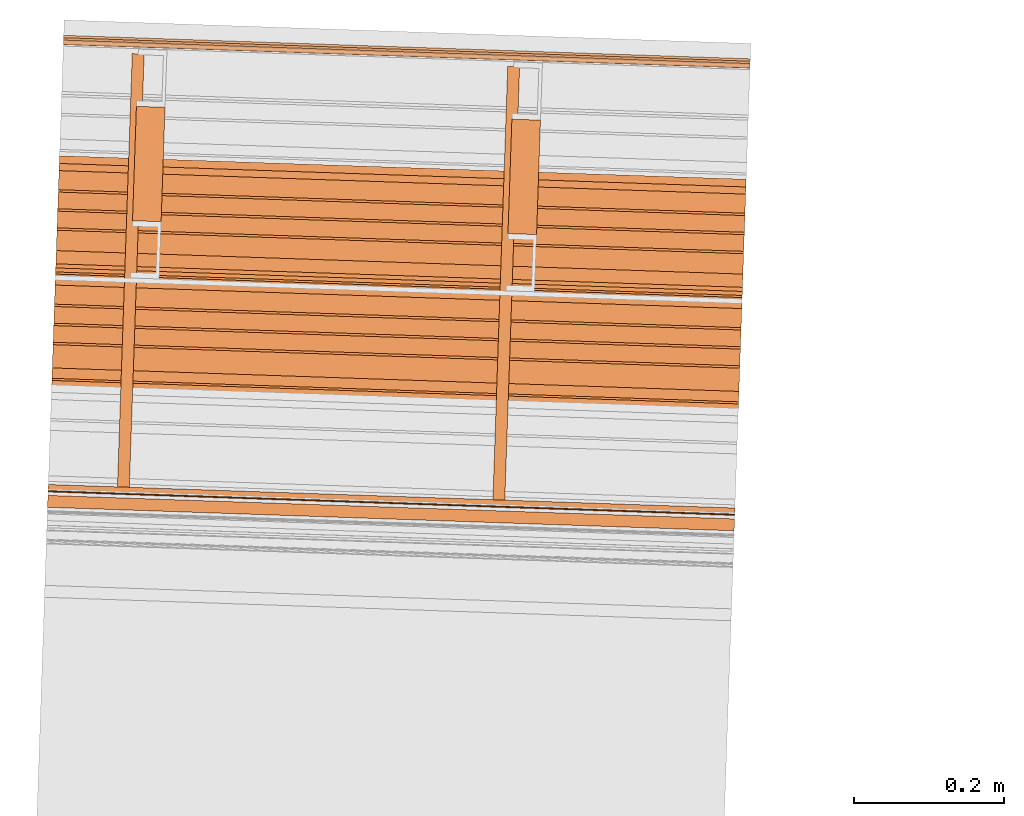
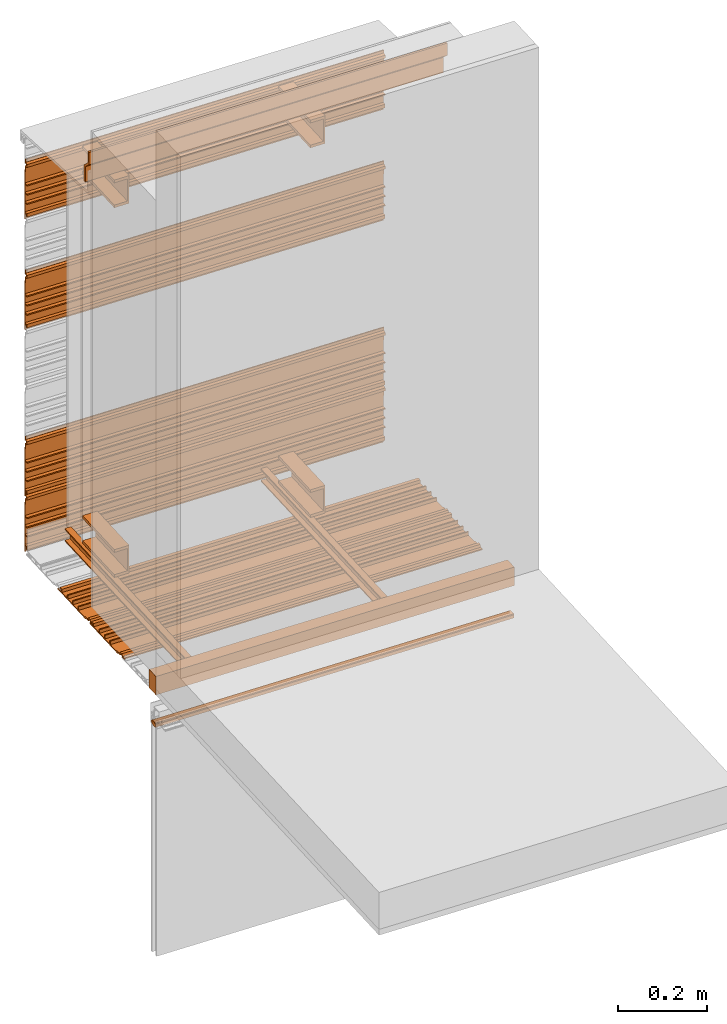
# One storey, part 4 of 6: 17 proxies.
"""IFC2X3 building model written with IfcOpenShell, lengths in feet."""

import ifcopenshell
import ifcopenshell.guid

model = None  # the IFC model being written
_history = None  # IfcOwnerHistory: only IFC2X3 demands one
_inside = {}  # id of a spatial element -> (the spatial element, [elements in it])
_under = {}  # id of a project, library or spatial element -> (it, [spatial elements below it])
_declared = {}  # id of a project -> (the project, [libraries it declares])
_typed = {}  # id of a type object -> (the type object, [elements of that type])
_made_of = {}  # id of a material, layer set ... -> (it, [elements and type objects made of it])


def new_model(schema):
    """Start an empty IFC model of exactly this schema.

    Asked for "IFC4X3", IfcOpenShell would pick the latest addendum, in which some entities
    have other attributes; the version numbers below select the first issue.
    IFC2X3 requires an IfcOwnerHistory on every rooted entity: one is made here for all.
    """
    global model, _history
    if schema == "IFC4X3":
        model = ifcopenshell.file(schema_version=(4, 3, 0, 0))
    else:
        model = ifcopenshell.file(schema=schema)
    _inside.clear()
    _under.clear()
    _declared.clear()
    _typed.clear()
    _made_of.clear()
    _history = None
    if model.schema == "IFC2X3":
        org = make("IfcOrganization", Name="unknown")
        user = make(
            "IfcPersonAndOrganization",
            ThePerson=make("IfcPerson", FamilyName="unknown"),
            TheOrganization=org,
        )
        app = make(
            "IfcApplication",
            ApplicationDeveloper=org,
            Version="unknown",
            ApplicationFullName="unknown",
            ApplicationIdentifier="unknown",
        )
        _history = make(
            "IfcOwnerHistory",
            OwningUser=user,
            OwningApplication=app,
            ChangeAction="ADDED",
            CreationDate=0,
        )
    return model


def make(cls, **values):
    """One entity of the class cls with the attributes given. An attribute that is None is left unset."""
    return model.create_entity(
        cls, **{name: value for name, value in values.items() if value is not None}
    )


def entity(cls, *values):
    """Any entity or typed value of the class cls, its attributes in the order of the schema. None: left unset."""
    e = model.create_entity(cls)
    for i, value in enumerate(values):
        if value is not None:
            e[i] = value
    return e


def rooted(cls, **values):
    """An entity with a GlobalId (a new one), such as an element, a storey or a relation."""
    return make(cls, GlobalId=ifcopenshell.guid.new(), OwnerHistory=_history, **values)


def si_unit(unit_type, name, prefix=None):
    """IfcSIUnit, for example si_unit("LENGTHUNIT", "METRE", prefix="MILLI")."""
    return make("IfcSIUnit", UnitType=unit_type, Prefix=prefix, Name=name)


def converted_unit(unit_type, name, factor, base, dimensions=None, offset=None):
    """IfcConversionBasedUnit, such as the inch: factor (a typed value) times the base unit."""
    return make(
        "IfcConversionBasedUnit"
        if offset is None
        else "IfcConversionBasedUnitWithOffset",
        ConversionOffset=offset,
        Dimensions=None
        if dimensions is None
        else entity("IfcDimensionalExponents", *dimensions),
        UnitType=unit_type,
        Name=name,
        ConversionFactor=make(
            "IfcMeasureWithUnit", ValueComponent=factor, UnitComponent=base
        ),
    )


def derived_unit(unit_type, elements):
    """IfcDerivedUnit: a product of units, each with its exponent."""
    return make(
        "IfcDerivedUnit",
        Elements=[
            make("IfcDerivedUnitElement", Unit=unit, Exponent=power)
            for unit, power in elements
        ],
        UnitType=unit_type,
    )


def assignment(units):
    """IfcUnitAssignment: the units of a project."""
    return None if units is None else make("IfcUnitAssignment", Units=units)


def point(xyz):
    """IfcCartesianPoint."""
    return None if xyz is None else make("IfcCartesianPoint", Coordinates=xyz)


def direction(xyz):
    """IfcDirection."""
    return None if xyz is None else make("IfcDirection", DirectionRatios=xyz)


def frame(location, z_axis=None, x_axis=None):
    """IfcAxis2Placement3D, a coordinate frame: its origin and axes. An axis left out is left unset."""
    return make(
        "IfcAxis2Placement3D",
        Location=point(location),
        Axis=direction(z_axis),
        RefDirection=direction(x_axis),
    )


def frame_2d(location, x_axis=None):
    """IfcAxis2Placement2D, a coordinate frame in the plane: its origin and x axis."""
    return make(
        "IfcAxis2Placement2D", Location=point(location), RefDirection=direction(x_axis)
    )


def origin():
    """The frame at (0, 0, 0) with its axes left unset."""
    return frame((0.0, 0.0, 0.0))


def place(relative_to, where):
    """IfcLocalPlacement: puts the frame where relative to a parent placement (None: the world)."""
    return make(
        "IfcLocalPlacement", PlacementRelTo=relative_to, RelativePlacement=where
    )


def context(
    kind, dimensions, precision=None, world=None, true_north=None, identifier=None
):
    """IfcGeometricRepresentationContext, for example the 3D "Model" context."""
    return make(
        "IfcGeometricRepresentationContext",
        ContextIdentifier=identifier,
        ContextType=kind,
        CoordinateSpaceDimension=dimensions,
        Precision=precision,
        WorldCoordinateSystem=world,
        TrueNorth=true_north,
    )


def subcontext(parent, identifier, kind, view, scale=None):
    """IfcGeometricRepresentationSubContext, for example "Body" below "Model"."""
    return make(
        "IfcGeometricRepresentationSubContext",
        ContextIdentifier=identifier,
        ContextType=kind,
        ParentContext=parent,
        TargetScale=scale,
        TargetView=view,
    )


def project(units=None, contexts=None):
    """IfcProject with its units and contexts."""
    return rooted(
        "IfcProject",
        Name="project",
        RepresentationContexts=contexts,
        UnitsInContext=assignment(units),
    )


def spatial(cls, under=None, at=None, **own):
    """A site, building, storey or space (cls), placed at a placement, below another one or the project."""
    s = rooted(cls, ObjectPlacement=at, **own)
    if under is not None:
        _under.setdefault(under.id(), (under, []))[1].append(s)
    return s


def polyline(points):
    """IfcPolyline through the points."""
    return make("IfcPolyline", Points=[point(p) for p in points])


def circle_curve(where, radius):
    """IfcCircle in the frame where."""
    return make("IfcCircle", Position=where, Radius=radius)


def parameter(value):
    """IfcParameterValue: where a trimmed curve begins or ends, as a parameter of its basis curve."""
    return model.create_entity("IfcParameterValue", value)


def trimmed(basis, trim1, trim2, sense, master):
    """IfcTrimmedCurve: the piece of a basis curve between two trims."""
    return make(
        "IfcTrimmedCurve",
        BasisCurve=basis,
        Trim1=trim1,
        Trim2=trim2,
        SenseAgreement=sense,
        MasterRepresentation=master,
    )


def segment(curve, same_sense, transition):
    """IfcCompositeCurveSegment."""
    return make(
        "IfcCompositeCurveSegment",
        Transition=transition,
        SameSense=same_sense,
        ParentCurve=curve,
    )


def composite_curve(segments, self_intersect=None):
    """IfcCompositeCurve: segments joined end to end."""
    return make("IfcCompositeCurve", Segments=segments, SelfIntersect=self_intersect)


def profile(cls, at=None, kind="AREA", **sizes):
    """A parametric profile (cls). Its sizes go by their IFC names, for example OverallWidth=200.0."""
    return make(cls, ProfileType=kind, Position=at, **sizes)


def rectangle(**sizes):
    """IfcRectangleProfileDef."""
    return profile("IfcRectangleProfileDef", **sizes)


def outline(outer, holes=None, kind="AREA"):
    """IfcArbitraryClosedProfileDef: a profile drawn as a closed curve; with holes, ...WithVoids."""
    if holes is None:
        return make("IfcArbitraryClosedProfileDef", ProfileType=kind, OuterCurve=outer)
    return make(
        "IfcArbitraryProfileDefWithVoids",
        ProfileType=kind,
        OuterCurve=outer,
        InnerCurves=holes,
    )


def extrude(swept, where, along, depth):
    """IfcExtrudedAreaSolid: the profile swept, set in the frame where, extruded along a direction by depth."""
    return make(
        "IfcExtrudedAreaSolid",
        SweptArea=swept,
        Position=where,
        ExtrudedDirection=direction(along),
        Depth=depth,
    )


def shape(context_of_items, identifier, shape_type, items):
    """IfcShapeRepresentation: the items that make up one representation, for example the "Body"."""
    return make(
        "IfcShapeRepresentation",
        ContextOfItems=context_of_items,
        RepresentationIdentifier=identifier,
        RepresentationType=shape_type,
        Items=items,
    )


def source(mapping_origin, context_of_items, identifier, shape_type, items):
    """IfcRepresentationMap: a shape defined once, which mapped items show again and again."""
    return make(
        "IfcRepresentationMap",
        MappingOrigin=mapping_origin,
        MappedRepresentation=shape(context_of_items, identifier, shape_type, items),
    )


def transform(
    local_origin,
    x_axis=None,
    y_axis=None,
    z_axis=None,
    scale=None,
    scale2=None,
    scale3=None,
    uniform=True,
):
    """IfcCartesianTransformationOperator3D, or its non-uniform kind. x_axis, y_axis, z_axis: its Axis1, 2, 3."""
    if uniform:
        return make(
            "IfcCartesianTransformationOperator3D",
            Axis1=direction(x_axis),
            Axis2=direction(y_axis),
            LocalOrigin=point(local_origin),
            Scale=scale,
            Axis3=direction(z_axis),
        )
    return make(
        "IfcCartesianTransformationOperator3DnonUniform",
        Axis1=direction(x_axis),
        Axis2=direction(y_axis),
        LocalOrigin=point(local_origin),
        Scale=scale,
        Axis3=direction(z_axis),
        Scale2=scale2,
        Scale3=scale3,
    )


def mapped(mapping_source, mapping_target):
    """IfcMappedItem: shows the shape of a source again, moved by a transform."""
    return make(
        "IfcMappedItem", MappingSource=mapping_source, MappingTarget=mapping_target
    )


def material(Name=None, Category=None):
    """IfcMaterial."""
    return make("IfcMaterial", Name=Name, Category=Category)


def made_of(thing, what):
    """Note that an element or type object is made of a material, layer set ...; save() writes the relation."""
    if what is not None:
        _made_of.setdefault(what.id(), (what, []))[1].append(thing)
    return thing


def type_object(cls, material=None, **own):
    """A type object (cls), such as IfcWallType, which elements share."""
    return made_of(rooted(cls, **own), material)


def type_shapes(of_type, sources):
    """Give a type object the sources (RepresentationMaps) that its elements show as mapped items."""
    of_type.RepresentationMaps = sources


def element(
    cls,
    number,
    at=None,
    inside=None,
    cuts=None,
    type_object=None,
    material=None,
    context=None,
    identifier="Body",
    shape_type=None,
    held_by="IfcProductDefinitionShape",
    body=None,
    shapes=None,
    **own,
):
    """One element of the class cls, such as IfcWall. Its Tag is "e" and its number.

    at: its placement. inside: the storey or other place that contains it. cuts: it is an
    opening in that element (IfcRelVoidsElement). A single representation is given by context,
    identifier, shape_type and body (its items); several are given by shapes. held_by: the class
    of the entity that holds the representations. save() writes the other relations.
    """
    e = rooted(cls, Tag="e%d" % number, ObjectPlacement=at, **own)
    if body is not None:
        shapes = [shape(context, identifier, shape_type, body)]
    if shapes is not None:
        e.Representation = make(held_by, Representations=shapes)
    if inside is not None:
        _inside.setdefault(inside.id(), (inside, []))[1].append(e)
    if cuts is not None:
        rooted(
            "IfcRelVoidsElement", RelatingBuildingElement=cuts, RelatedOpeningElement=e
        )
    if type_object is not None:
        _typed.setdefault(type_object.id(), (type_object, []))[1].append(e)
    return made_of(e, material)


def aggregate(whole, parts):
    """IfcRelAggregates: a whole, such as a stair, and the parts it consists of."""
    return rooted("IfcRelAggregates", RelatingObject=whole, RelatedObjects=parts)


def save(model, path):
    """Write the relations noted so far, then the file.

    IfcRelAggregates (storeys below a building ...), IfcRelContainedInSpatialStructure (elements
    in a storey), IfcRelDefinesByType, IfcRelAssociatesMaterial and IfcRelDeclares: one each for
    every whole, place, type object, material and project.
    """
    for whole, parts in _under.values():
        aggregate(whole, parts)
    for where, things in _inside.values():
        rooted(
            "IfcRelContainedInSpatialStructure",
            RelatedElements=things,
            RelatingStructure=where,
        )
    for kind, things in _typed.values():
        rooted("IfcRelDefinesByType", RelatedObjects=things, RelatingType=kind)
    for what, things in _made_of.values():
        rooted("IfcRelAssociatesMaterial", RelatedObjects=things, RelatingMaterial=what)
    for by, libraries in _declared.values():
        rooted("IfcRelDeclares", RelatingContext=by, RelatedDefinitions=libraries)
    model.write(path)


model = new_model("IFC2X3")

# Units and contexts
model_context = context("Model", 3, precision=0.0001, world=origin(), true_north=direction((6.12303176911189e-17, 1.0)))
context_of_model = context(None, 3, precision=0.0001, world=origin(), true_north=direction((6.12303176911189e-17, 1.0)))
body_context = subcontext(model_context, "Body", "Model", "MODEL_VIEW")
ifc_project = project(units=[converted_unit("LENGTHUNIT", "FOOT", entity("IfcRatioMeasure", 0.3048), si_unit("LENGTHUNIT", "METRE"), dimensions=[1, 0, 0, 0, 0, 0, 0]), converted_unit("AREAUNIT", "SQUARE FOOT", entity("IfcRatioMeasure", 0.09290304), si_unit("AREAUNIT", "SQUARE_METRE"), dimensions=[2, 0, 0, 0, 0, 0, 0]), si_unit("VOLUMEUNIT", "CUBIC_METRE"), converted_unit("PLANEANGLEUNIT", "DEGREE", entity("IfcRatioMeasure", 0.0174532925199433), si_unit("PLANEANGLEUNIT", "RADIAN"), dimensions=[0, 0, 0, 0, 0, 0, 0]), si_unit("MASSUNIT", "GRAM", prefix="KILO"), derived_unit("MASSDENSITYUNIT", [(si_unit("MASSUNIT", "GRAM", prefix="KILO"), 1), (si_unit("LENGTHUNIT", "METRE"), -3)]), si_unit("TIMEUNIT", "SECOND"), si_unit("FREQUENCYUNIT", "HERTZ"), si_unit("THERMODYNAMICTEMPERATUREUNIT", "DEGREE_CELSIUS"), derived_unit("THERMALTRANSMITTANCEUNIT", [(si_unit("MASSUNIT", "GRAM", prefix="KILO"), 1), (si_unit("THERMODYNAMICTEMPERATUREUNIT", "KELVIN"), -1), (si_unit("TIMEUNIT", "SECOND"), -3)]), derived_unit("VOLUMETRICFLOWRATEUNIT", [(si_unit("LENGTHUNIT", "METRE"), 3), (si_unit("TIMEUNIT", "SECOND"), -1)]), si_unit("ELECTRICCURRENTUNIT", "AMPERE"), si_unit("ELECTRICVOLTAGEUNIT", "VOLT"), si_unit("POWERUNIT", "WATT"), si_unit("FORCEUNIT", "NEWTON"), si_unit("ILLUMINANCEUNIT", "LUX"), si_unit("LUMINOUSFLUXUNIT", "LUMEN"), si_unit("LUMINOUSINTENSITYUNIT", "CANDELA"), derived_unit("USERDEFINED", [(si_unit("MASSUNIT", "GRAM", prefix="KILO"), -1), (si_unit("LENGTHUNIT", "METRE"), -2), (si_unit("TIMEUNIT", "SECOND"), 3), (si_unit("LUMINOUSFLUXUNIT", "LUMEN"), 1)]), derived_unit("LINEARVELOCITYUNIT", [(si_unit("LENGTHUNIT", "METRE"), 1), (si_unit("TIMEUNIT", "SECOND"), -1)]), si_unit("PRESSUREUNIT", "PASCAL"), derived_unit("USERDEFINED", [(si_unit("LENGTHUNIT", "METRE"), -2), (si_unit("MASSUNIT", "GRAM", prefix="KILO"), 1), (si_unit("TIMEUNIT", "SECOND"), -2)])], contexts=[model_context, context_of_model])

# Site, building, storey
site_placement = place(None, origin())
site = spatial("IfcSite", under=ifc_project, at=site_placement, CompositionType="ELEMENT")
building_placement = place(site_placement, origin())
building = spatial("IfcBuilding", under=site, at=building_placement, CompositionType="ELEMENT")
storey_placement = place(building_placement, origin())
storey = spatial("IfcBuildingStorey", under=building, at=storey_placement, Name="Level 1", CompositionType="ELEMENT", Elevation=0.0)

# Proxies
ifc_material_1 = material(Name="IfcSurfaceStyle #179")
building_element_proxy_type_1 = type_object("IfcBuildingElementProxyType", Name="Metal support for window frame001", PredefinedType="NOTDEFINED", material=ifc_material_1)
shared_shape_1 = source(origin(), body_context, "Body", "SweptSolid", [
    extrude(rectangle(XDim=3.0, YDim=0.107278015091847, at=frame_2d((-6.99440505513849e-15, -2.42861286636753e-16), x_axis=(1.0, 0.0))), frame((111.216846057744, -50.6154050021282, 9.70833333333332), z_axis=(0.0, 0.0, 1.0), x_axis=(-0.999414947916634, 0.0342017818364937, 0.0)), (0.0, 0.0, 1.0), 0.166666666666668),
])
type_shapes(building_element_proxy_type_1, [shared_shape_1])
proxy_1_placement = place(storey_placement, origin())
element("IfcBuildingElementProxy", 1, at=proxy_1_placement, inside=storey, type_object=building_element_proxy_type_1, material=ifc_material_1, ObjectType="Metal support for window frame001", context=body_context, shape_type="MappedRepresentation", body=[
    mapped(shared_shape_1, transform((0.0, 0.0, 0.0), scale=1.0)),
])
ifc_material_2 = material(Name="LIGHT GAUGE METAL STUDS AND/OR FURRING")
building_element_proxy_type_2 = type_object("IfcBuildingElementProxyType", Name="Stud 004", PredefinedType="NOTDEFINED", material=ifc_material_2)
shared_shape_2 = source(origin(), body_context, "Body", "SweptSolid", [
    extrude(outline(polyline([(-0.0286458333333562, -0.0572916666666679), (0.0234374999999827, -0.0572916666666679), (0.0234374999999827, -0.046875), (-0.0182291666666801, -0.046875), (-0.0182291666666801, 0.046875), (0.0234374999999827, 0.046875), (0.0234374999999827, 0.0572916666666661), (-0.0286458333333562, 0.0572916666666661), (-0.0286458333333562, -0.0572916666666679)])), frame((110.044847585689, -50.5216266933335, 9.81770833333333), z_axis=(0.0342017818365511, 0.999414947916632, 0.0), x_axis=(-0.999414947916632, 0.0342017818365511, 0.0)), (0.0, 0.0, 1.0), 1.89272198512796),
])
type_shapes(building_element_proxy_type_2, [shared_shape_2])
proxy_2_placement = place(storey_placement, origin())
element("IfcBuildingElementProxy", 2, at=proxy_2_placement, inside=storey, type_object=building_element_proxy_type_2, material=ifc_material_2, Name="Stud 004:Stud 004", ObjectType="Stud 004", context=body_context, shape_type="MappedRepresentation", body=[
    mapped(shared_shape_2, transform((0.0, 0.0, 0.0), scale=1.0)),
])
building_element_proxy_type_3 = type_object("IfcBuildingElementProxyType", Name="Stud 003", PredefinedType="NOTDEFINED", material=ifc_material_2)
shared_shape_3 = source(origin(), body_context, "Body", "SweptSolid", [
    extrude(outline(polyline([(-0.0286458333333278, -0.0572916666666679), (0.023437500000025, -0.0572916666666679), (0.023437500000025, -0.046875), (-0.0182291666666514, -0.046875), (-0.0182291666666514, 0.046875), (0.023437500000025, 0.046875), (0.023437500000025, 0.0572916666666661), (-0.0286458333333278, 0.0572916666666661), (-0.0286458333333278, -0.0572916666666679)])), frame((111.684307802088, -50.5777319784982, 9.81770833333333), z_axis=(0.0342017818364056, 0.999414947916637, 0.0), x_axis=(-0.999414947916637, 0.0342017818364056, 0.0)), (0.0, 0.0, 1.0), 1.89272198512795),
])
type_shapes(building_element_proxy_type_3, [shared_shape_3])
proxy_3_placement = place(storey_placement, origin())
element("IfcBuildingElementProxy", 3, at=proxy_3_placement, inside=storey, type_object=building_element_proxy_type_3, material=ifc_material_2, Name="Stud 003:Stud 003", ObjectType="Stud 003", context=body_context, shape_type="MappedRepresentation", body=[
    mapped(shared_shape_3, transform((0.0, 0.0, 0.0), scale=1.0)),
])
ifc_material_3 = material(Name="METAL STUDS")
building_element_proxy_type_4 = type_object("IfcBuildingElementProxyType", Name="Metal stud 014", PredefinedType="NOTDEFINED", material=ifc_material_3)
shared_shape_4 = source(origin(), body_context, "Body", "SweptSolid", [
    extrude(outline(polyline([(-0.0661909448818519, -0.125), (0.0588090551181219, -0.125), (0.0588090551181219, -0.100393700787402), (-0.0514271653543063, -0.100393700787402), (-0.0514271653543063, 0.100393700787404), (0.0588090551181219, 0.100393700787404), (0.0588090551181219, 0.125000000000002), (-0.0661909448818519, 0.125000000000002), (-0.0661909448818519, -0.125)])), frame((110.146020542697, -49.3608525569486, 10.0), z_axis=(0.0342017818366075, 0.99941494791663, 0.0), x_axis=(-0.99941494791663, 0.0342017818366075, 0.0)), (0.0, 0.0, 1.0), 0.500000000000002),
])
type_shapes(building_element_proxy_type_4, [shared_shape_4])
proxy_4_placement = place(storey_placement, origin())
element("IfcBuildingElementProxy", 4, at=proxy_4_placement, inside=storey, type_object=building_element_proxy_type_4, material=ifc_material_3, Name="Metal stud 014:Metal stud 014", ObjectType="Metal stud 014", context=body_context, shape_type="MappedRepresentation", body=[
    mapped(shared_shape_4, transform((0.0, 0.0, 0.0), scale=1.0)),
])
building_element_proxy_type_5 = type_object("IfcBuildingElementProxyType", Name="Metal stud 011", PredefinedType="NOTDEFINED", material=ifc_material_3)
shared_shape_5 = source(origin(), body_context, "Body", "SweptSolid", [
    extrude(outline(polyline([(-0.0661909448818519, -0.125), (0.0588090551181219, -0.125), (0.0588090551181219, -0.1003937007874), (-0.0514271653543063, -0.1003937007874), (-0.0514271653543063, 0.1003937007874), (0.0588090551181219, 0.1003937007874), (0.0588090551181219, 0.125), (-0.0661909448818519, 0.125), (-0.0661909448818519, -0.125)])), frame((110.146020542697, -49.3608525569486, 13.3333333333333), z_axis=(0.0342017818366075, 0.99941494791663, 0.0), x_axis=(-0.99941494791663, 0.0342017818366075, 0.0)), (0.0, 0.0, 1.0), 0.500000000000002),
])
type_shapes(building_element_proxy_type_5, [shared_shape_5])
proxy_5_placement = place(storey_placement, origin())
element("IfcBuildingElementProxy", 5, at=proxy_5_placement, inside=storey, type_object=building_element_proxy_type_5, material=ifc_material_3, Name="Metal stud 011:Metal stud 011", ObjectType="Metal stud 011", context=body_context, shape_type="MappedRepresentation", body=[
    mapped(shared_shape_5, transform((0.0, 0.0, 0.0), scale=1.0)),
])
building_element_proxy_type_6 = type_object("IfcBuildingElementProxyType", Name="Metal stud 013", PredefinedType="NOTDEFINED", material=ifc_material_3)
shared_shape_6 = source(origin(), body_context, "Body", "SweptSolid", [
    extrude(outline(polyline([(-0.0661909448818803, -0.125), (0.0588090551181075, -0.125), (0.0588090551181075, -0.1003937007874), (-0.0514271653543347, -0.1003937007874), (-0.0514271653543347, 0.1003937007874), (0.0588090551181075, 0.1003937007874), (0.0588090551181075, 0.125), (-0.0661909448818803, 0.125), (-0.0661909448818803, -0.125)])), frame((111.785480759096, -49.4169578421136, 13.3333333333333), z_axis=(0.0342017818365468, 0.999414947916633, 0.0), x_axis=(-0.999414947916633, 0.0342017818365468, 0.0)), (0.0, 0.0, 1.0), 0.500000000000001),
])
type_shapes(building_element_proxy_type_6, [shared_shape_6])
proxy_6_placement = place(storey_placement, origin())
element("IfcBuildingElementProxy", 6, at=proxy_6_placement, inside=storey, type_object=building_element_proxy_type_6, material=ifc_material_3, Name="Metal stud 013:Metal stud 013", ObjectType="Metal stud 013", context=body_context, shape_type="MappedRepresentation", body=[
    mapped(shared_shape_6, transform((0.0, 0.0, 0.0), scale=1.0)),
])
building_element_proxy_type_7 = type_object("IfcBuildingElementProxyType", Name="Metal stud 012", PredefinedType="NOTDEFINED", material=ifc_material_3)
shared_shape_7 = source(origin(), body_context, "Body", "SweptSolid", [
    extrude(outline(polyline([(-0.0661909448818803, -0.125), (0.0588090551181075, -0.125), (0.0588090551181075, -0.100393700787402), (-0.0514271653543347, -0.100393700787402), (-0.0514271653543347, 0.100393700787404), (0.0588090551181075, 0.100393700787404), (0.0588090551181075, 0.125000000000002), (-0.0661909448818803, 0.125000000000002), (-0.0661909448818803, -0.125)])), frame((111.785480759096, -49.4169578421136, 10.0), z_axis=(0.0342017818365468, 0.999414947916633, 0.0), x_axis=(-0.999414947916633, 0.0342017818365468, 0.0)), (0.0, 0.0, 1.0), 0.500000000000001),
])
type_shapes(building_element_proxy_type_7, [shared_shape_7])
proxy_7_placement = place(storey_placement, origin())
element("IfcBuildingElementProxy", 7, at=proxy_7_placement, inside=storey, type_object=building_element_proxy_type_7, material=ifc_material_3, Name="Metal stud 012:Metal stud 012", ObjectType="Metal stud 012", context=body_context, shape_type="MappedRepresentation", body=[
    mapped(shared_shape_7, transform((0.0, 0.0, 0.0), scale=1.0)),
])
ifc_material_4 = material(Name="IMPERMEABLE WRB MEMBRANE")
building_element_proxy_type_8 = type_object("IfcBuildingElementProxyType", Name="Flashing 003", PredefinedType="NOTDEFINED", material=ifc_material_4)
shared_shape_8 = source(origin(), body_context, "Body", "SweptSolid", [
    extrude(outline(polyline([(-0.0371589137820224, 0.0154669259900354), (-0.135772181632417, -0.0923404467542823), (-0.122552267089255, -0.104432931160668), (-0.0292661571907254, -0.00244938836847988), (0.0490662805214159, -0.0024493883946275), (0.123864814921589, 0.0793229091327372), (0.110644900349842, 0.0914153935652706), (0.0411735239015335, 0.0154669259900354), (-0.0371589137820224, 0.0154669259900354)])), frame((109.753215664138, -49.5269849138619, 13.807758480938), z_axis=(-0.999414947916625, 0.0342017818367569, 0.0), x_axis=(-0.025236475786405, -0.737438512825177, 0.674942634667624)), (0.0, 0.0, -1.0), 3.0),
])
type_shapes(building_element_proxy_type_8, [shared_shape_8])
proxy_8_placement = place(storey_placement, origin())
element("IfcBuildingElementProxy", 8, at=proxy_8_placement, inside=storey, type_object=building_element_proxy_type_8, material=ifc_material_4, Name="Flashing 003:Flashing 003", ObjectType="Flashing 003", context=body_context, shape_type="MappedRepresentation", body=[
    mapped(shared_shape_8, transform((0.0, 0.0, 0.0), scale=1.0)),
])
ifc_material_5 = material(Name="Window frame")
building_element_proxy_type_9 = type_object("IfcBuildingElementProxyType", Name="Window frame 017", PredefinedType="NOTDEFINED", material=ifc_material_5)
shared_shape_9 = source(origin(), body_context, "Body", "SweptSolid", [
    extrude(outline(composite_curve([segment(polyline([(-0.0145833333334195, -0.0259583333333165), (0.0145833333334213, -0.0259583333333165)]), True, "CONTINUOUS"), segment(trimmed(circle_curve(frame_2d((-0.118933680555463, 0.0), x_axis=(0.0, -1.0)), 0.13601701388888), [parameter(78.9978270971977)], [parameter(101.002172902812)], True, "PARAMETER"), True, "CONTINUOUS"), segment(polyline([(0.0145833333334178, 0.0259583333333232), (-0.014583333333416, 0.0259583333333232)]), True, "CONTINUOUS"), segment(trimmed(circle_curve(frame_2d((0.118933680555465, 0.0), x_axis=(0.0, -1.0)), 0.13601701388888), [parameter(258.997827097188)], [parameter(281.002172902802)], True, "PARAMETER"), True, "CONTINUOUS")], self_intersect=False)), frame((109.717039781299, -50.5840853372173, 9.42538449904838), z_axis=(0.999414947916641, -0.0342017818362893, 0.0), x_axis=(0.0, 0.0, -1.0)), (0.0, 0.0, 1.0), 3.0),
])
type_shapes(building_element_proxy_type_9, [shared_shape_9])
proxy_9_placement = place(storey_placement, origin())
element("IfcBuildingElementProxy", 9, at=proxy_9_placement, inside=storey, type_object=building_element_proxy_type_9, material=ifc_material_5, Name="Window frame 017:Window frame 017", ObjectType="Window frame 017", context=body_context, shape_type="MappedRepresentation", body=[
    mapped(shared_shape_9, transform((0.0, 0.0, 0.0), scale=1.0)),
])
building_element_proxy_type_10 = type_object("IfcBuildingElementProxyType", Name="Window frame 014", PredefinedType="NOTDEFINED", material=ifc_material_5)
shared_shape_10 = source(origin(), body_context, "Body", "SweptSolid", [
    extrude(rectangle(XDim=3.0, YDim=0.00499999999997292, at=frame_2d((6.99440505513849e-15, 3.7921055184853e-15), x_axis=(1.0, 0.0))), frame((111.217669931724, -50.5913304676835, 9.4124678323819), z_axis=(0.0, 0.0, 1.0), x_axis=(-0.999414947916663, 0.0342017818356482, 0.0)), (0.0, 0.0, 1.0), 0.0208333333333339),
])
type_shapes(building_element_proxy_type_10, [shared_shape_10])
proxy_10_placement = place(storey_placement, origin())
element("IfcBuildingElementProxy", 10, at=proxy_10_placement, inside=storey, type_object=building_element_proxy_type_10, material=ifc_material_5, Name="Window frame 014:Window frame 014", ObjectType="Window frame 014", context=body_context, shape_type="MappedRepresentation", body=[
    mapped(shared_shape_10, transform((0.0, 0.0, 0.0), scale=1.0)),
])
ifc_material_6 = material()
building_element_proxy_type_11 = type_object("IfcBuildingElementProxyType", Name="panel 021", PredefinedType="NOTDEFINED", material=ifc_material_6)
shared_shape_11 = source(origin(), body_context, "Body", "SweptSolid", [
    extrude(outline(polyline([(-0.0220175316851953, 0.145680147068472), (-0.0220175316851953, -0.291819852931525), (-0.0116008650185187, -0.291819852931525), (-0.0116008650185187, -0.237132352931535), (0.00451787028331154, -0.237132352931535), (0.00451787028331154, -0.257965686264864), (0.0173047730392253, -0.257965686264864), (0.0173047730392253, -0.226715686264859), (-0.0116008650185187, -0.226715686264859), (-0.0116008650185187, -0.143382352931519), (0.0196491349814752, -0.143382352931519), (0.0196491349814752, -0.132965686264868), (-0.0116008650185187, -0.132965686264868), (-0.0116008650185187, -0.060049019598182), (0.0196491349814752, -0.060049019598182), (0.0196491349814752, -0.0496323529315283), (-0.0116008650185187, -0.0496323529315283), (-0.0116008650185187, 0.0232843137351324), (0.0196491349814752, 0.0232843137351324), (0.0196491349814752, 0.0337009804018091), (-0.0116008650185187, 0.0337009804018091), (-0.0116008650185187, 0.135263480401818), (-0.00118419835184916, 0.135263480401818), (-0.00118419835184916, 0.1807106651131), (0.0186287630982651, 0.18994960080863), (0.0186287630982651, 0.215994026661653), (-0.00118419835184916, 0.225232962029098), (-0.00118419835184916, 0.249846813735138), (-0.0116008650185187, 0.249846813735138), (-0.0116008650185187, 0.218596813735132), (0.0061931721533835, 0.210299318000235), (0.0061931721533835, 0.195644309470049), (-0.0116008650185187, 0.187346813735152), (-0.0116008650185187, 0.145680147068472), (-0.0220175316851953, 0.145680147068472)])), frame((109.785926286855, -48.5711433305344, 12.021009163627), z_axis=(-0.999414947916601, 0.034201781837477, 0.0), x_axis=(-0.034201781837477, -0.999414947916601, 0.0)), (0.0, 0.0, -1.0), 3.0),
])
type_shapes(building_element_proxy_type_11, [shared_shape_11])
proxy_11_placement = place(storey_placement, origin())
element("IfcBuildingElementProxy", 11, at=proxy_11_placement, inside=storey, type_object=building_element_proxy_type_11, material=ifc_material_6, Name="panel 021:panel 021", ObjectType="panel 021", context=body_context, shape_type="MappedRepresentation", body=[
    mapped(shared_shape_11, transform((0.0, 0.0, 0.0), scale=1.0)),
])
building_element_proxy_type_12 = type_object("IfcBuildingElementProxyType", Name="panel 018", PredefinedType="NOTDEFINED", material=ifc_material_6)
shared_shape_12 = source(origin(), body_context, "Body", "SweptSolid", [
    extrude(outline(polyline([(-0.291819852941177, -0.011600865003091), (-0.291819852941177, -0.0220175316697446), (0.145680147058845, -0.0220175316697446), (0.145680147058845, -0.011600865003091), (0.187346813725486, -0.011600865003091), (0.195644309526018, 0.00619317207041981), (0.210299317924977, 0.00619317207041981), (0.218596813725508, -0.011600865003091), (0.24984681372553, -0.011600865003091), (0.24984681372553, -0.00118419833641603), (0.225232962281936, -0.00118419833641603), (0.215994026619204, 0.0186287629496675), (0.189949600831819, 0.0186287629496675), (0.18071066516908, -0.00118419833641603), (0.135263480392169, -0.00118419833641603), (0.135263480392169, -0.011600865003091), (0.0337009803921564, -0.011600865003091), (0.0337009803921564, 0.0196491349969126), (0.0232843137255086, 0.0196491349969126), (0.0232843137255086, -0.011600865003091), (-0.0496323529411549, -0.011600865003091), (-0.0496323529411549, 0.0196491349969126), (-0.0600490196078311, 0.0196491349969126), (-0.0600490196078311, -0.011600865003091), (-0.132965686274494, -0.011600865003091), (-0.132965686274494, 0.0196491349969126), (-0.143382352941171, 0.0196491349969126), (-0.143382352941171, -0.011600865003091), (-0.22671568627451, -0.011600865003091), (-0.22671568627451, 0.0173047731202818), (-0.257965686274482, 0.0173047731202818), (-0.257965686274482, 0.00451787023313344), (-0.237132352941158, 0.00451787023313344), (-0.237132352941158, -0.011600865003091), (-0.291819852941177, -0.011600865003091)])), frame((109.741606113486, -49.8662291822323, 9.73037350903191), z_axis=(-0.999414947916631, 0.0342017818365886, 0.0), x_axis=(-0.0342017818365886, -0.999414947916631, 0.0)), (0.0, 0.0, -1.0), 2.99999999999999),
])
type_shapes(building_element_proxy_type_12, [shared_shape_12])
proxy_12_placement = place(storey_placement, origin())
element("IfcBuildingElementProxy", 12, at=proxy_12_placement, inside=storey, type_object=building_element_proxy_type_12, material=ifc_material_6, Name="panel 018:panel 018", ObjectType="panel 018", context=body_context, shape_type="MappedRepresentation", body=[
    mapped(shared_shape_12, transform((0.0, 0.0, 0.0), scale=1.0)),
])
building_element_proxy_type_13 = type_object("IfcBuildingElementProxyType", Name="Window frame 013", PredefinedType="NOTDEFINED", material=ifc_material_5)
shared_shape_13 = source(origin(), body_context, "Body", "SweptSolid", [
    extrude(outline(composite_curve([segment(polyline([(-0.00499999999991374, -0.0259583333333165), (0.00499999999991552, -0.0259583333333165)]), True, "CONTINUOUS"), segment(polyline([(0.00499999999991552, -0.0259583333333165), (0.00499999999991552, 0.0259583333333232)]), True, "CONTINUOUS"), segment(polyline([(0.00499999999991552, 0.0259583333333232), (-0.00499999999991729, 0.0259583333333232)]), True, "CONTINUOUS"), segment(trimmed(circle_curve(frame_2d((-0.138517013888798, 0.0), x_axis=(0.0, 1.0)), 0.13601701388888), [parameter(258.997827097198)], [parameter(281.002172902812)], True, "PARAMETER"), False, "CONTINUOUS")], self_intersect=False)), frame((109.717039781299, -50.5840853372173, 9.44496783238197), z_axis=(0.999414947916633, -0.0342017818365487, 0.0), x_axis=(0.0, 0.0, 1.0)), (0.0, 0.0, 1.0), 3.0),
])
type_shapes(building_element_proxy_type_13, [shared_shape_13])
proxy_13_placement = place(storey_placement, origin())
element("IfcBuildingElementProxy", 13, at=proxy_13_placement, inside=storey, type_object=building_element_proxy_type_13, material=ifc_material_5, Name="Window frame 013:Window frame 013", ObjectType="Window frame 013", context=body_context, shape_type="MappedRepresentation", body=[
    mapped(shared_shape_13, transform((0.0, 0.0, 0.0), scale=1.0)),
])
building_element_proxy_type_14 = type_object("IfcBuildingElementProxyType", Name="panel 015", PredefinedType="NOTDEFINED", material=ifc_material_6)
shared_shape_14 = source(origin(), body_context, "Body", "SweptSolid", [
    extrude(outline(polyline([(-0.0220175316851953, 0.14568014706847), (-0.0220175316851953, -0.291819852931527), (-0.0116008650185187, -0.291819852931527), (-0.0116008650185187, -0.237132352931535), (0.00451787028331154, -0.237132352931535), (0.00451787028331154, -0.257965686264864), (0.0173047730392253, -0.257965686264864), (0.0173047730392253, -0.22671568626486), (-0.0116008650185187, -0.22671568626486), (-0.0116008650185187, -0.143382352931521), (0.0196491349814752, -0.143382352931521), (0.0196491349814752, -0.132965686264869), (-0.0116008650185187, -0.132965686264869), (-0.0116008650185187, -0.0600490195981838), (0.0196491349814752, -0.0600490195981838), (0.0196491349814752, -0.0496323529315301), (-0.0116008650185187, -0.0496323529315301), (-0.0116008650185187, 0.0232843137351306), (0.0196491349814752, 0.0232843137351306), (0.0196491349814752, 0.0337009804018074), (-0.0116008650185187, 0.0337009804018074), (-0.0116008650185187, 0.135263480401818), (-0.00118419835184916, 0.135263480401818), (-0.00118419835184916, 0.180710665113098), (0.0186287630982651, 0.18994960080863), (0.0186287630982651, 0.215994026661651), (-0.00118419835184916, 0.225232962029096), (-0.00118419835184916, 0.249846813735136), (-0.0116008650185187, 0.249846813735136), (-0.0116008650185187, 0.218596813735131), (0.0061931721533835, 0.210299318000233), (0.0061931721533835, 0.195644309470049), (-0.0116008650185187, 0.18734681373515), (-0.0116008650185187, 0.14568014706847), (-0.0220175316851953, 0.14568014706847)])), frame((109.785926286855, -48.5711433305344, 10.521009163627), z_axis=(-0.999414947916601, 0.034201781837477, 0.0), x_axis=(-0.034201781837477, -0.999414947916601, 0.0)), (0.0, 0.0, -1.0), 3.0),
])
type_shapes(building_element_proxy_type_14, [shared_shape_14])
proxy_14_placement = place(storey_placement, origin())
element("IfcBuildingElementProxy", 14, at=proxy_14_placement, inside=storey, type_object=building_element_proxy_type_14, material=ifc_material_6, Name="panel 015:panel 015", ObjectType="panel 015", context=body_context, shape_type="MappedRepresentation", body=[
    mapped(shared_shape_14, transform((0.0, 0.0, 0.0), scale=1.0)),
])
building_element_proxy_type_15 = type_object("IfcBuildingElementProxyType", Name="panel 019", PredefinedType="NOTDEFINED", material=ifc_material_6)
shared_shape_15 = source(origin(), body_context, "Body", "SweptSolid", [
    extrude(outline(polyline([(-0.0220175316851953, 0.145680147068473), (-0.0220175316851953, -0.291819852931525), (-0.0116008650185187, -0.291819852931525), (-0.0116008650185187, -0.237132352931534), (0.00451787028331154, -0.237132352931534), (0.00451787028331154, -0.257965686264862), (0.0173047730392253, -0.257965686264862), (0.0173047730392253, -0.226715686264859), (-0.0116008650185187, -0.226715686264859), (-0.0116008650185187, -0.143382352931518), (0.0196491349814752, -0.143382352931518), (0.0196491349814752, -0.132965686264868), (-0.0116008650185187, -0.132965686264868), (-0.0116008650185187, -0.0600490195981802), (0.0196491349814752, -0.0600490195981802), (0.0196491349814752, -0.0496323529315266), (-0.0116008650185187, -0.0496323529315266), (-0.0116008650185187, 0.0232843137351324), (0.0196491349814752, 0.0232843137351324), (0.0196491349814752, 0.0337009804018109), (-0.0116008650185187, 0.0337009804018109), (-0.0116008650185187, 0.13526348040182), (-0.00118419835184916, 0.13526348040182), (-0.00118419835184916, 0.1807106651131), (0.0186287630982651, 0.189949600808632), (0.0186287630982651, 0.215994026661653), (-0.00118419835184916, 0.2252329620291), (-0.00118419835184916, 0.24984681373514), (-0.0116008650185187, 0.24984681373514), (-0.0116008650185187, 0.218596813735132), (0.0061931721533835, 0.210299318000237), (0.0061931721533835, 0.195644309470051), (-0.0116008650185187, 0.187346813735154), (-0.0116008650185187, 0.145680147068473), (-0.0220175316851953, 0.145680147068473)])), frame((109.785926286855, -48.5711433305344, 13.021009163627), z_axis=(-0.999414947916601, 0.034201781837477, 0.0), x_axis=(-0.034201781837477, -0.999414947916601, 0.0)), (0.0, 0.0, -1.0), 3.0),
])
type_shapes(building_element_proxy_type_15, [shared_shape_15])
proxy_15_placement = place(storey_placement, origin())
element("IfcBuildingElementProxy", 15, at=proxy_15_placement, inside=storey, type_object=building_element_proxy_type_15, material=ifc_material_6, Name="panel 019:panel 019", ObjectType="panel 019", context=body_context, shape_type="MappedRepresentation", body=[
    mapped(shared_shape_15, transform((0.0, 0.0, 0.0), scale=1.0)),
])
building_element_proxy_type_16 = type_object("IfcBuildingElementProxyType", Name="panel 024", PredefinedType="NOTDEFINED", material=ifc_material_6)
shared_shape_16 = source(origin(), body_context, "Body", "SweptSolid", [
    extrude(outline(polyline([(-0.0220175316851953, 0.145680147068473), (-0.0220175316851953, -0.291819852931523), (-0.0116008650185187, -0.291819852931523), (-0.0116008650185187, -0.237132352931534), (0.00451787028331154, -0.237132352931534), (0.00451787028331154, -0.257965686264862), (0.0173047730392253, -0.257965686264862), (0.0173047730392253, -0.226715686264857), (-0.0116008650185187, -0.226715686264857), (-0.0116008650185187, -0.143382352931519), (0.0196491349814752, -0.143382352931519), (0.0196491349814752, -0.132965686264866), (-0.0116008650185187, -0.132965686264866), (-0.0116008650185187, -0.0600490195981802), (0.0196491349814752, -0.0600490195981802), (0.0196491349814752, -0.0496323529315283), (-0.0116008650185187, -0.0496323529315283), (-0.0116008650185187, 0.0232843137351342), (0.0196491349814752, 0.0232843137351342), (0.0196491349814752, 0.0337009804018091), (-0.0116008650185187, 0.0337009804018091), (-0.0116008650185187, 0.13526348040182), (-0.00118419835184916, 0.13526348040182), (-0.00118419835184916, 0.1807106651131), (0.0186287630982651, 0.189949600808632), (0.0186287630982651, 0.215994026661653), (-0.00118419835184916, 0.2252329620291), (-0.00118419835184916, 0.249846813735138), (-0.0116008650185187, 0.249846813735138), (-0.0116008650185187, 0.218596813735134), (0.0061931721533835, 0.210299318000235), (0.0061931721533835, 0.195644309470051), (-0.0116008650185187, 0.187346813735154), (-0.0116008650185187, 0.145680147068473), (-0.0220175316851953, 0.145680147068473)])), frame((109.785926286855, -48.5711433305344, 10.021009163627), z_axis=(-0.999414947916601, 0.034201781837477, 0.0), x_axis=(-0.034201781837477, -0.999414947916601, 0.0)), (0.0, 0.0, -1.0), 3.0),
])
type_shapes(building_element_proxy_type_16, [shared_shape_16])
proxy_16_placement = place(storey_placement, origin())
element("IfcBuildingElementProxy", 16, at=proxy_16_placement, inside=storey, type_object=building_element_proxy_type_16, material=ifc_material_6, Name="panel 024:panel 024", ObjectType="panel 024", context=body_context, shape_type="MappedRepresentation", body=[
    mapped(shared_shape_16, transform((0.0, 0.0, 0.0), scale=1.0)),
])
building_element_proxy_type_17 = type_object("IfcBuildingElementProxyType", Name="panel 017", PredefinedType="NOTDEFINED", material=ifc_material_6)
shared_shape_17 = source(origin(), body_context, "Body", "SweptSolid", [
    extrude(outline(polyline([(-0.291819852941174, -0.011600865003091), (-0.291819852941174, -0.0220175316697446), (0.145680147058836, -0.0220175316697446), (0.145680147058836, -0.011600865003091), (0.187346813725485, -0.011600865003091), (0.195644309526024, 0.00619317207041981), (0.210299317924975, 0.00619317207041981), (0.218596813725506, -0.011600865003091), (0.249846813725521, -0.011600865003091), (0.249846813725521, -0.00118419833641603), (0.225232962281941, -0.00118419833641603), (0.215994026619209, 0.0186287629496675), (0.18994960083181, 0.0186287629496675), (0.180710665169079, -0.00118419833641603), (0.135263480392167, -0.00118419833641603), (0.135263480392167, -0.011600865003091), (0.0337009803921559, -0.011600865003091), (0.0337009803921559, 0.0196491349969126), (0.0232843137255081, 0.0196491349969126), (0.0232843137255081, -0.011600865003091), (-0.0496323529411615, -0.011600865003091), (-0.0496323529411615, 0.0196491349969126), (-0.0600490196078306, 0.0196491349969126), (-0.0600490196078306, -0.011600865003091), (-0.1329656862745, -0.011600865003091), (-0.1329656862745, 0.0196491349969126), (-0.143382352941169, 0.0196491349969126), (-0.143382352941169, -0.011600865003091), (-0.226715686274508, -0.011600865003091), (-0.226715686274508, 0.0173047731202818), (-0.25796568627448, 0.0173047731202818), (-0.25796568627448, 0.00451787023313344), (-0.237132352941156, 0.00451787023313344), (-0.237132352941156, -0.011600865003091), (-0.291819852941174, -0.011600865003091)])), frame((109.758707004404, -49.366521708274, 9.73037350903191), z_axis=(-0.99941494791664, 0.034201781836329, 0.0), x_axis=(-0.034201781836329, -0.99941494791664, 0.0)), (0.0, 0.0, -1.0), 3.0),
])
type_shapes(building_element_proxy_type_17, [shared_shape_17])
proxy_17_placement = place(storey_placement, origin())
element("IfcBuildingElementProxy", 17, at=proxy_17_placement, inside=storey, type_object=building_element_proxy_type_17, material=ifc_material_6, Name="panel 017:panel 017", ObjectType="panel 017", context=body_context, shape_type="MappedRepresentation", body=[
    mapped(shared_shape_17, transform((0.0, 0.0, 0.0), scale=1.0)),
])

save(model, "model.ifc")
